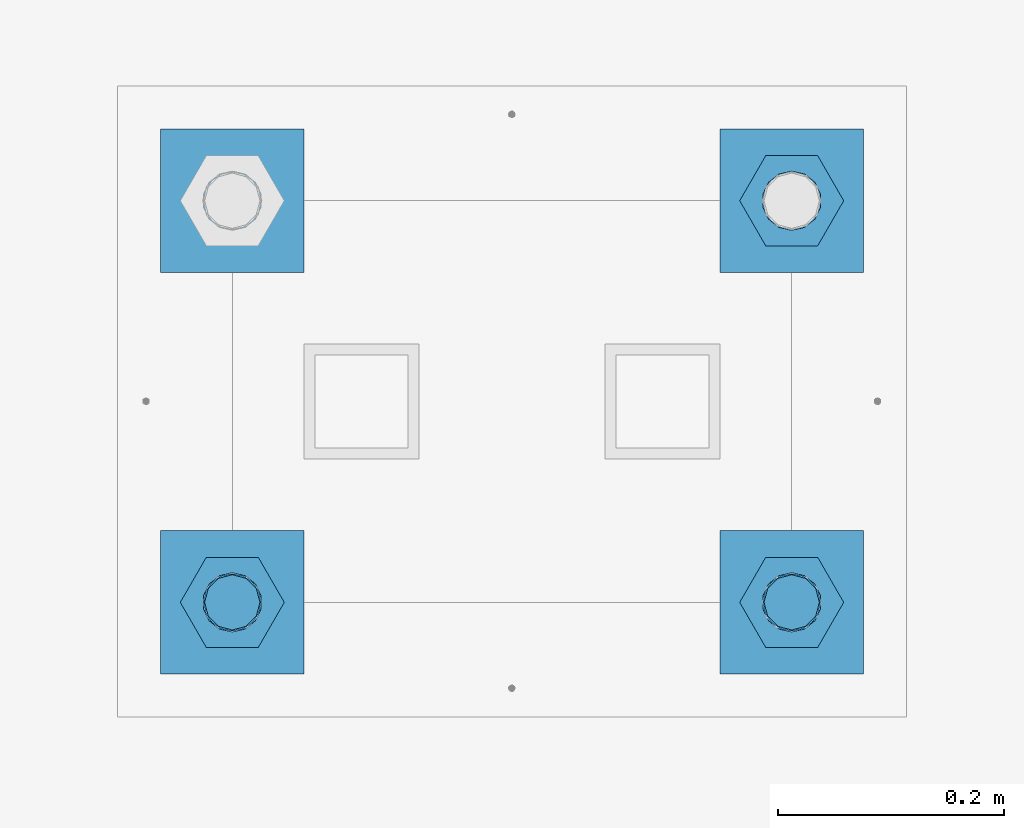
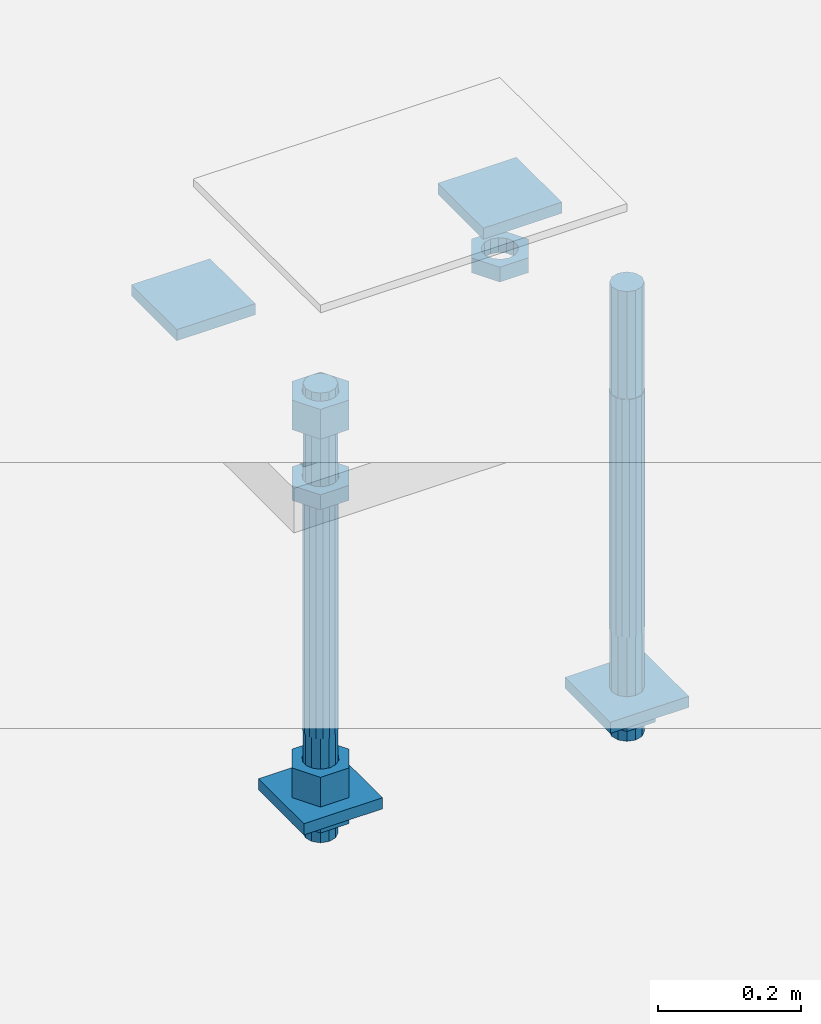
# One storey, part 2704 of 3843: 12 beams, 1 element without a shape of its own.
"""IFC2X3 building model written with IfcOpenShell, lengths in millimetres."""

from ifc_helpers import new_model, si_unit, frame, origin_with_axes, place, context, subcontext, project, spatial, faceted_brep, material, type_object, element, aggregate, save


model = new_model("IFC2X3")

# Units and contexts
model_context = context("Model", 3, precision=1e-05, world=origin_with_axes())
body_context = subcontext(model_context, "Body", "Model", "MODEL_VIEW")
ifc_project = project(units=[si_unit("LENGTHUNIT", "METRE", prefix="MILLI"), si_unit("AREAUNIT", "SQUARE_METRE"), si_unit("VOLUMEUNIT", "CUBIC_METRE"), si_unit("MASSUNIT", "GRAM", prefix="KILO"), si_unit("TIMEUNIT", "SECOND"), si_unit("PLANEANGLEUNIT", "RADIAN"), si_unit("SOLIDANGLEUNIT", "STERADIAN"), si_unit("THERMODYNAMICTEMPERATUREUNIT", "DEGREE_CELSIUS"), si_unit("LUMINOUSINTENSITYUNIT", "LUMEN")], contexts=[model_context])

# Site, building, storey
site_placement = place(None, origin_with_axes())
site = spatial("IfcSite", under=ifc_project, at=site_placement, CompositionType="ELEMENT")
building_placement = place(site_placement, origin_with_axes())
building = spatial("IfcBuilding", under=site, at=building_placement, Name="Undefined", CompositionType="ELEMENT")
storey_placement = place(building_placement, origin_with_axes())
storey = spatial("IfcBuildingStorey", under=building, at=storey_placement, Name="Undefined", CompositionType="ELEMENT", Elevation=0.0)

# Assembly, beams
assembly_placement = place(storey_placement, origin_with_axes())
assembly = element("IfcElementAssembly", 1, at=assembly_placement, inside=storey, Name="TEMPLATE", AssemblyPlace="NOTDEFINED", PredefinedType="RIGID_FRAME")
ifc_material_1 = material(Name="STEEL/A572-50")
beam_type_1 = type_object("IfcBeamType", PredefinedType="NOTDEFINED")
beam_1_placement = place(assembly_placement, frame((105403.65, 45910.4999984741, 29873.575), z_axis=(-1.0, 0.0, 0.0), x_axis=(0.0, -1.0, 0.0)))
beam_1 = element("IfcBeam", 2, at=beam_1_placement, type_object=beam_type_1, material=ifc_material_1, Name="WASHER_PLATE", context=body_context, shape_type="Brep", body=[
    faceted_brep([(0.0, 9.52500000000146, -63.5), (0.0, 9.52500000000146, 63.5), (127.0, 9.52500000000146, 63.5), (127.0, 9.52500000000146, -63.5), (0.0, -9.52500000000146, 63.5), (127.0, -9.52500000000146, 63.5), (0.0, -9.52500000000146, -63.5), (127.0, -9.52500000000146, -63.5)], [[[0, 1, 2, 3]], [[1, 4, 5, 2]], [[4, 6, 7, 5]], [[6, 0, 3, 7]], [[5, 7, 3, 2]], [[6, 4, 1, 0]]]),
])
beam_2_placement = place(assembly_placement, frame((104908.35, 45910.4999984741, 29873.575), z_axis=(-1.0, 0.0, 0.0), x_axis=(0.0, -1.0, 0.0)))
beam_2 = element("IfcBeam", 3, at=beam_2_placement, type_object=beam_type_1, material=ifc_material_1, Name="WASHER_PLATE", context=body_context, shape_type="Brep", body=[
    faceted_brep([(0.0, 9.52500000000146, -63.5), (0.0, 9.52500000000146, 63.5), (127.0, 9.52500000000146, 63.5), (127.0, 9.52500000000146, -63.5), (0.0, -9.52500000000146, 63.5), (127.0, -9.52500000000146, 63.5), (0.0, -9.52500000000146, -63.5), (127.0, -9.52500000000146, -63.5)], [[[0, 1, 2, 3]], [[1, 4, 5, 2]], [[4, 6, 7, 5]], [[6, 0, 3, 7]], [[5, 7, 3, 2]], [[6, 4, 1, 0]]]),
])
beam_3_placement = place(assembly_placement, frame((105403.65, 45554.8999984741, 29244.925), z_axis=(-1.0, 0.0, 0.0), x_axis=(0.0, -1.0, 0.0)))
beam_3 = element("IfcBeam", 4, at=beam_3_placement, type_object=beam_type_1, material=ifc_material_1, Name="WASHER_PLATE", context=body_context, shape_type="Brep", body=[
    faceted_brep([(0.0, 9.52500000000146, -63.5), (0.0, 9.52500000000146, 63.5), (127.0, 9.52500000000146, 63.5), (127.0, 9.52500000000146, -63.5), (0.0, -9.52500000000146, 63.5), (127.0, -9.52500000000146, 63.5), (0.0, -9.52500000000146, -63.5), (127.0, -9.52500000000146, -63.5)], [[[0, 1, 2, 3]], [[1, 4, 5, 2]], [[4, 6, 7, 5]], [[6, 0, 3, 7]], [[5, 7, 3, 2]], [[6, 4, 1, 0]]]),
])
beam_4_placement = place(assembly_placement, frame((104908.35, 45554.8999984741, 29244.925), z_axis=(-1.0, 0.0, 0.0), x_axis=(0.0, -1.0, 0.0)))
beam_4 = element("IfcBeam", 5, at=beam_4_placement, type_object=beam_type_1, material=ifc_material_1, Name="WASHER_PLATE", context=body_context, shape_type="Brep", body=[
    faceted_brep([(0.0, 9.52500000000146, -63.5), (0.0, 9.52500000000146, 63.5), (127.0, 9.52500000000146, 63.5), (127.0, 9.52500000000146, -63.5), (0.0, -9.52500000000146, 63.5), (127.0, -9.52500000000146, 63.5), (0.0, -9.52500000000146, -63.5), (127.0, -9.52500000000146, -63.5)], [[[0, 1, 2, 3]], [[1, 4, 5, 2]], [[4, 6, 7, 5]], [[6, 0, 3, 7]], [[5, 7, 3, 2]], [[6, 4, 1, 0]]]),
])
ifc_material_2 = material(Name="STEEL/A36")
beam_type_2 = type_object("IfcBeamType", Name="2_HALF_NUT", PredefinedType="NOTDEFINED")
beam_5_placement = place(assembly_placement, frame((105403.65, 45846.9999984741, 29787.85), z_axis=(0.0, -1.0, 0.0), x_axis=(0.0, 0.0, -1.0)))
beam_5 = element("IfcBeam", 6, at=beam_5_placement, type_object=beam_type_2, material=ifc_material_2, Name="NUT", ObjectType="2_HALF_NUT", context=body_context, shape_type="Brep", body=[
    faceted_brep([(0.0, -46.0369987487793, 0.0), (0.0, -23.0184993743896, -39.869213104248), (25.4000000000015, -23.0184993743896, -39.869213104248), (25.4000000000015, -46.0369987487793, 0.0), (0.0, 23.0184993743896, -39.869213104248), (25.4000000000015, 23.0184993743896, -39.869213104248), (0.0, 46.0369987487793, 0.0), (25.4000000000015, 46.0369987487793, 0.0), (0.0, 23.0184993743896, 39.869213104248), (25.4000000000015, 23.0184993743896, 39.869213104248), (0.0, -23.0184993743896, 39.869213104248), (25.4000000000015, -23.0184993743896, 39.869213104248), (0.0, 0.0, 26.1940002441406), (0.0, 11.3650617044477, 23.5999013092805), (25.4000000000015, 11.3650617044477, 23.5999013092805), (25.4000000000015, 0.0, 26.1940002441406), (0.0, 20.4791109456419, 16.3316083006721), (25.4000000000015, 20.4791109456419, 16.3316083006721), (0.0, 25.5370200498292, 5.82867859874386), (25.4000000000015, 25.5370200498292, 5.82867859874386), (0.0, 25.5370200498292, -5.82867859874386), (25.4000000000015, 25.5370200498292, -5.82867859874386), (0.0, 20.4791109456419, -16.3316083006721), (25.4000000000015, 20.4791109456419, -16.3316083006721), (0.0, 11.3650617044477, -23.5999013092805), (25.4000000000015, 11.3650617044477, -23.5999013092805), (0.0, 0.0, -26.1940002441406), (25.4000000000015, 0.0, -26.1940002441406), (0.0, -11.3650617044477, -23.5999013092805), (25.4000000000015, -11.3650617044477, -23.5999013092805), (0.0, -20.4791109456419, -16.3316083006721), (25.4000000000015, -20.4791109456419, -16.3316083006721), (0.0, -25.5370200498292, -5.82867859874386), (25.4000000000015, -25.5370200498292, -5.82867859874386), (0.0, -25.5370200498292, 5.82867859874386), (25.4000000000015, -25.5370200498292, 5.82867859874386), (0.0, -20.4791109456419, 16.3316083006721), (25.4000000000015, -20.4791109456419, 16.3316083006721), (0.0, -11.3650617044477, 23.5999013092805), (25.4000000000015, -11.3650617044477, 23.5999013092805)], [[[0, 1, 2, 3]], [[1, 4, 5, 2]], [[4, 6, 7, 5]], [[6, 8, 9, 7]], [[8, 10, 11, 9]], [[10, 0, 3, 11]], [[12, 13, 14, 15]], [[13, 16, 17, 14]], [[16, 18, 19, 17]], [[18, 20, 21, 19]], [[20, 22, 23, 21]], [[22, 24, 25, 23]], [[24, 26, 27, 25]], [[26, 28, 29, 27]], [[28, 30, 31, 29]], [[30, 32, 33, 31]], [[32, 34, 35, 33]], [[34, 36, 37, 35]], [[36, 38, 39, 37]], [[38, 12, 15, 39]], [[5, 7, 9, 11, 3, 2], [17, 19, 21, 23, 25, 27, 29, 31, 33, 35, 37, 39, 15, 14]], [[10, 8, 6, 4, 1, 0], [38, 36, 34, 32, 30, 28, 26, 24, 22, 20, 18, 16, 13, 12]]]),
])
beam_6_placement = place(assembly_placement, frame((105403.65, 45491.3999984741, 29235.4), z_axis=(0.0, -1.0, 0.0), x_axis=(0.0, 0.0, -1.0)))
beam_6 = element("IfcBeam", 7, at=beam_6_placement, type_object=beam_type_2, material=ifc_material_2, Name="NUT", ObjectType="2_HALF_NUT", context=body_context, shape_type="Brep", body=[
    faceted_brep([(0.0, -46.0369987487793, 0.0), (0.0, -23.0184993743896, -39.869213104248), (25.4000000000015, -23.0184993743896, -39.869213104248), (25.4000000000015, -46.0369987487793, 0.0), (0.0, 23.0184993743896, -39.869213104248), (25.4000000000015, 23.0184993743896, -39.869213104248), (0.0, 46.0369987487793, 0.0), (25.4000000000015, 46.0369987487793, 0.0), (0.0, 23.0184993743896, 39.869213104248), (25.4000000000015, 23.0184993743896, 39.869213104248), (0.0, -23.0184993743896, 39.869213104248), (25.4000000000015, -23.0184993743896, 39.869213104248), (0.0, 0.0, 26.1940002441406), (0.0, 11.3650617044477, 23.5999013092805), (25.4000000000015, 11.3650617044477, 23.5999013092805), (25.4000000000015, 0.0, 26.1940002441406), (0.0, 20.4791109456419, 16.3316083006721), (25.4000000000015, 20.4791109456419, 16.3316083006721), (0.0, 25.5370200498292, 5.82867859874386), (25.4000000000015, 25.5370200498292, 5.82867859874386), (0.0, 25.5370200498292, -5.82867859874386), (25.4000000000015, 25.5370200498292, -5.82867859874386), (0.0, 20.4791109456419, -16.3316083006721), (25.4000000000015, 20.4791109456419, -16.3316083006721), (0.0, 11.3650617044477, -23.5999013092805), (25.4000000000015, 11.3650617044477, -23.5999013092805), (0.0, 0.0, -26.1940002441406), (25.4000000000015, 0.0, -26.1940002441406), (0.0, -11.3650617044477, -23.5999013092805), (25.4000000000015, -11.3650617044477, -23.5999013092805), (0.0, -20.4791109456419, -16.3316083006721), (25.4000000000015, -20.4791109456419, -16.3316083006721), (0.0, -25.5370200498292, -5.82867859874386), (25.4000000000015, -25.5370200498292, -5.82867859874386), (0.0, -25.5370200498292, 5.82867859874386), (25.4000000000015, -25.5370200498292, 5.82867859874386), (0.0, -20.4791109456419, 16.3316083006721), (25.4000000000015, -20.4791109456419, 16.3316083006721), (0.0, -11.3650617044477, 23.5999013092805), (25.4000000000015, -11.3650617044477, 23.5999013092805)], [[[0, 1, 2, 3]], [[1, 4, 5, 2]], [[4, 6, 7, 5]], [[6, 8, 9, 7]], [[8, 10, 11, 9]], [[10, 0, 3, 11]], [[12, 13, 14, 15]], [[13, 16, 17, 14]], [[16, 18, 19, 17]], [[18, 20, 21, 19]], [[20, 22, 23, 21]], [[22, 24, 25, 23]], [[24, 26, 27, 25]], [[26, 28, 29, 27]], [[28, 30, 31, 29]], [[30, 32, 33, 31]], [[32, 34, 35, 33]], [[34, 36, 37, 35]], [[36, 38, 39, 37]], [[38, 12, 15, 39]], [[5, 7, 9, 11, 3, 2], [17, 19, 21, 23, 25, 27, 29, 31, 33, 35, 37, 39, 15, 14]], [[10, 8, 6, 4, 1, 0], [38, 36, 34, 32, 30, 28, 26, 24, 22, 20, 18, 16, 13, 12]]]),
])
beam_7_placement = place(assembly_placement, frame((104908.35, 45491.3999984741, 29787.85), z_axis=(0.0, -1.0, 0.0), x_axis=(0.0, 0.0, -1.0)))
beam_7 = element("IfcBeam", 8, at=beam_7_placement, type_object=beam_type_2, material=ifc_material_2, Name="NUT", ObjectType="2_HALF_NUT", context=body_context, shape_type="Brep", body=[
    faceted_brep([(0.0, -46.0369987487793, 0.0), (0.0, -23.0184993743896, -39.869213104248), (25.4000000000015, -23.0184993743896, -39.869213104248), (25.4000000000015, -46.0369987487793, 0.0), (0.0, 23.0184993743896, -39.869213104248), (25.4000000000015, 23.0184993743896, -39.869213104248), (0.0, 46.0369987487793, 0.0), (25.4000000000015, 46.0369987487793, 0.0), (0.0, 23.0184993743896, 39.869213104248), (25.4000000000015, 23.0184993743896, 39.869213104248), (0.0, -23.0184993743896, 39.869213104248), (25.4000000000015, -23.0184993743896, 39.869213104248), (0.0, 0.0, 26.1940002441406), (0.0, 11.3650617044477, 23.5999013092805), (25.4000000000015, 11.3650617044477, 23.5999013092805), (25.4000000000015, 0.0, 26.1940002441406), (0.0, 20.4791109456419, 16.3316083006721), (25.4000000000015, 20.4791109456419, 16.3316083006721), (0.0, 25.5370200498292, 5.82867859874386), (25.4000000000015, 25.5370200498292, 5.82867859874386), (0.0, 25.5370200498292, -5.82867859874386), (25.4000000000015, 25.5370200498292, -5.82867859874386), (0.0, 20.4791109456419, -16.3316083006721), (25.4000000000015, 20.4791109456419, -16.3316083006721), (0.0, 11.3650617044477, -23.5999013092805), (25.4000000000015, 11.3650617044477, -23.5999013092805), (0.0, 0.0, -26.1940002441406), (25.4000000000015, 0.0, -26.1940002441406), (0.0, -11.3650617044477, -23.5999013092805), (25.4000000000015, -11.3650617044477, -23.5999013092805), (0.0, -20.4791109456419, -16.3316083006721), (25.4000000000015, -20.4791109456419, -16.3316083006721), (0.0, -25.5370200498292, -5.82867859874386), (25.4000000000015, -25.5370200498292, -5.82867859874386), (0.0, -25.5370200498292, 5.82867859874386), (25.4000000000015, -25.5370200498292, 5.82867859874386), (0.0, -20.4791109456419, 16.3316083006721), (25.4000000000015, -20.4791109456419, 16.3316083006721), (0.0, -11.3650617044477, 23.5999013092805), (25.4000000000015, -11.3650617044477, 23.5999013092805)], [[[0, 1, 2, 3]], [[1, 4, 5, 2]], [[4, 6, 7, 5]], [[6, 8, 9, 7]], [[8, 10, 11, 9]], [[10, 0, 3, 11]], [[12, 13, 14, 15]], [[13, 16, 17, 14]], [[16, 18, 19, 17]], [[18, 20, 21, 19]], [[20, 22, 23, 21]], [[22, 24, 25, 23]], [[24, 26, 27, 25]], [[26, 28, 29, 27]], [[28, 30, 31, 29]], [[30, 32, 33, 31]], [[32, 34, 35, 33]], [[34, 36, 37, 35]], [[36, 38, 39, 37]], [[38, 12, 15, 39]], [[5, 7, 9, 11, 3, 2], [17, 19, 21, 23, 25, 27, 29, 31, 33, 35, 37, 39, 15, 14]], [[10, 8, 6, 4, 1, 0], [38, 36, 34, 32, 30, 28, 26, 24, 22, 20, 18, 16, 13, 12]]]),
])
beam_8_placement = place(assembly_placement, frame((104908.35, 45491.3999984741, 29235.4), z_axis=(0.0, -1.0, 0.0), x_axis=(0.0, 0.0, -1.0)))
beam_8 = element("IfcBeam", 9, at=beam_8_placement, type_object=beam_type_2, material=ifc_material_2, Name="NUT", ObjectType="2_HALF_NUT", context=body_context, shape_type="Brep", body=[
    faceted_brep([(0.0, -46.0369987487793, 0.0), (0.0, -23.0184993743896, -39.869213104248), (25.4000000000015, -23.0184993743896, -39.869213104248), (25.4000000000015, -46.0369987487793, 0.0), (0.0, 23.0184993743896, -39.869213104248), (25.4000000000015, 23.0184993743896, -39.869213104248), (0.0, 46.0369987487793, 0.0), (25.4000000000015, 46.0369987487793, 0.0), (0.0, 23.0184993743896, 39.869213104248), (25.4000000000015, 23.0184993743896, 39.869213104248), (0.0, -23.0184993743896, 39.869213104248), (25.4000000000015, -23.0184993743896, 39.869213104248), (0.0, 0.0, 26.1940002441406), (0.0, 11.3650617044477, 23.5999013092805), (25.4000000000015, 11.3650617044477, 23.5999013092805), (25.4000000000015, 0.0, 26.1940002441406), (0.0, 20.4791109456419, 16.3316083006721), (25.4000000000015, 20.4791109456419, 16.3316083006721), (0.0, 25.5370200498292, 5.82867859874386), (25.4000000000015, 25.5370200498292, 5.82867859874386), (0.0, 25.5370200498292, -5.82867859874386), (25.4000000000015, 25.5370200498292, -5.82867859874386), (0.0, 20.4791109456419, -16.3316083006721), (25.4000000000015, 20.4791109456419, -16.3316083006721), (0.0, 11.3650617044477, -23.5999013092805), (25.4000000000015, 11.3650617044477, -23.5999013092805), (0.0, 0.0, -26.1940002441406), (25.4000000000015, 0.0, -26.1940002441406), (0.0, -11.3650617044477, -23.5999013092805), (25.4000000000015, -11.3650617044477, -23.5999013092805), (0.0, -20.4791109456419, -16.3316083006721), (25.4000000000015, -20.4791109456419, -16.3316083006721), (0.0, -25.5370200498292, -5.82867859874386), (25.4000000000015, -25.5370200498292, -5.82867859874386), (0.0, -25.5370200498292, 5.82867859874386), (25.4000000000015, -25.5370200498292, 5.82867859874386), (0.0, -20.4791109456419, 16.3316083006721), (25.4000000000015, -20.4791109456419, 16.3316083006721), (0.0, -11.3650617044477, 23.5999013092805), (25.4000000000015, -11.3650617044477, 23.5999013092805)], [[[0, 1, 2, 3]], [[1, 4, 5, 2]], [[4, 6, 7, 5]], [[6, 8, 9, 7]], [[8, 10, 11, 9]], [[10, 0, 3, 11]], [[12, 13, 14, 15]], [[13, 16, 17, 14]], [[16, 18, 19, 17]], [[18, 20, 21, 19]], [[20, 22, 23, 21]], [[22, 24, 25, 23]], [[24, 26, 27, 25]], [[26, 28, 29, 27]], [[28, 30, 31, 29]], [[30, 32, 33, 31]], [[32, 34, 35, 33]], [[34, 36, 37, 35]], [[36, 38, 39, 37]], [[38, 12, 15, 39]], [[5, 7, 9, 11, 3, 2], [17, 19, 21, 23, 25, 27, 29, 31, 33, 35, 37, 39, 15, 14]], [[10, 8, 6, 4, 1, 0], [38, 36, 34, 32, 30, 28, 26, 24, 22, 20, 18, 16, 13, 12]]]),
])
beam_type_3 = type_object("IfcBeamType", Name="2_HEAVY_HEX_NUT", PredefinedType="NOTDEFINED")
beam_9_placement = place(assembly_placement, frame((104908.35, 45491.3999984741, 29933.9), z_axis=(0.0, -1.0, 0.0), x_axis=(0.0, 0.0, -1.0)))
beam_9 = element("IfcBeam", 10, at=beam_9_placement, type_object=beam_type_3, material=ifc_material_2, Name="NUT", ObjectType="2_HEAVY_HEX_NUT", context=body_context, shape_type="Brep", body=[
    faceted_brep([(0.0, -46.0369987487793, 0.0), (0.0, -23.0184993743896, -39.869213104248), (50.7999999999993, -23.0184993743896, -39.869213104248), (50.7999999999993, -46.0369987487793, 0.0), (0.0, 23.0184993743896, -39.869213104248), (50.7999999999993, 23.0184993743896, -39.869213104248), (0.0, 46.0369987487793, 0.0), (50.7999999999993, 46.0369987487793, 0.0), (0.0, 23.0184993743896, 39.869213104248), (50.7999999999993, 23.0184993743896, 39.869213104248), (0.0, -23.0184993743896, 39.869213104248), (50.7999999999993, -23.0184993743896, 39.869213104248), (0.0, 0.0, 26.1940002441406), (0.0, 11.3650617044477, 23.5999013092805), (50.7999999999993, 11.3650617044477, 23.5999013092805), (50.7999999999993, 0.0, 26.1940002441406), (0.0, 20.4791109456419, 16.3316083006721), (50.7999999999993, 20.4791109456419, 16.3316083006721), (0.0, 25.5370200498292, 5.82867859874386), (50.7999999999993, 25.5370200498292, 5.82867859874386), (0.0, 25.5370200498292, -5.82867859874386), (50.7999999999993, 25.5370200498292, -5.82867859874386), (0.0, 20.4791109456419, -16.3316083006721), (50.7999999999993, 20.4791109456419, -16.3316083006721), (0.0, 11.3650617044477, -23.5999013092805), (50.7999999999993, 11.3650617044477, -23.5999013092805), (0.0, 0.0, -26.1940002441406), (50.7999999999993, 0.0, -26.1940002441406), (0.0, -11.3650617044477, -23.5999013092805), (50.7999999999993, -11.3650617044477, -23.5999013092805), (0.0, -20.4791109456419, -16.3316083006721), (50.7999999999993, -20.4791109456419, -16.3316083006721), (0.0, -25.5370200498292, -5.82867859874386), (50.7999999999993, -25.5370200498292, -5.82867859874386), (0.0, -25.5370200498292, 5.82867859874386), (50.7999999999993, -25.5370200498292, 5.82867859874386), (0.0, -20.4791109456419, 16.3316083006721), (50.7999999999993, -20.4791109456419, 16.3316083006721), (0.0, -11.3650617044477, 23.5999013092805), (50.7999999999993, -11.3650617044477, 23.5999013092805)], [[[0, 1, 2, 3]], [[1, 4, 5, 2]], [[4, 6, 7, 5]], [[6, 8, 9, 7]], [[8, 10, 11, 9]], [[10, 0, 3, 11]], [[12, 13, 14, 15]], [[13, 16, 17, 14]], [[16, 18, 19, 17]], [[18, 20, 21, 19]], [[20, 22, 23, 21]], [[22, 24, 25, 23]], [[24, 26, 27, 25]], [[26, 28, 29, 27]], [[28, 30, 31, 29]], [[30, 32, 33, 31]], [[32, 34, 35, 33]], [[34, 36, 37, 35]], [[36, 38, 39, 37]], [[38, 12, 15, 39]], [[5, 7, 9, 11, 3, 2], [17, 19, 21, 23, 25, 27, 29, 31, 33, 35, 37, 39, 15, 14]], [[10, 8, 6, 4, 1, 0], [38, 36, 34, 32, 30, 28, 26, 24, 22, 20, 18, 16, 13, 12]]]),
])
beam_10_placement = place(assembly_placement, frame((104908.35, 45491.3999984741, 29305.25), z_axis=(0.0, -1.0, 0.0), x_axis=(0.0, 0.0, -1.0)))
beam_10 = element("IfcBeam", 11, at=beam_10_placement, type_object=beam_type_3, material=ifc_material_2, Name="NUT", ObjectType="2_HEAVY_HEX_NUT", context=body_context, shape_type="Brep", body=[
    faceted_brep([(0.0, -46.0369987487793, 0.0), (0.0, -23.0184993743896, -39.869213104248), (50.7999999999993, -23.0184993743896, -39.869213104248), (50.7999999999993, -46.0369987487793, 0.0), (0.0, 23.0184993743896, -39.869213104248), (50.7999999999993, 23.0184993743896, -39.869213104248), (0.0, 46.0369987487793, 0.0), (50.7999999999993, 46.0369987487793, 0.0), (0.0, 23.0184993743896, 39.869213104248), (50.7999999999993, 23.0184993743896, 39.869213104248), (0.0, -23.0184993743896, 39.869213104248), (50.7999999999993, -23.0184993743896, 39.869213104248), (0.0, 0.0, 26.1940002441406), (0.0, 11.3650617044477, 23.5999013092805), (50.7999999999993, 11.3650617044477, 23.5999013092805), (50.7999999999993, 0.0, 26.1940002441406), (0.0, 20.4791109456419, 16.3316083006721), (50.7999999999993, 20.4791109456419, 16.3316083006721), (0.0, 25.5370200498292, 5.82867859874386), (50.7999999999993, 25.5370200498292, 5.82867859874386), (0.0, 25.5370200498292, -5.82867859874386), (50.7999999999993, 25.5370200498292, -5.82867859874386), (0.0, 20.4791109456419, -16.3316083006721), (50.7999999999993, 20.4791109456419, -16.3316083006721), (0.0, 11.3650617044477, -23.5999013092805), (50.7999999999993, 11.3650617044477, -23.5999013092805), (0.0, 0.0, -26.1940002441406), (50.7999999999993, 0.0, -26.1940002441406), (0.0, -11.3650617044477, -23.5999013092805), (50.7999999999993, -11.3650617044477, -23.5999013092805), (0.0, -20.4791109456419, -16.3316083006721), (50.7999999999993, -20.4791109456419, -16.3316083006721), (0.0, -25.5370200498292, -5.82867859874386), (50.7999999999993, -25.5370200498292, -5.82867859874386), (0.0, -25.5370200498292, 5.82867859874386), (50.7999999999993, -25.5370200498292, 5.82867859874386), (0.0, -20.4791109456419, 16.3316083006721), (50.7999999999993, -20.4791109456419, 16.3316083006721), (0.0, -11.3650617044477, 23.5999013092805), (50.7999999999993, -11.3650617044477, 23.5999013092805)], [[[0, 1, 2, 3]], [[1, 4, 5, 2]], [[4, 6, 7, 5]], [[6, 8, 9, 7]], [[8, 10, 11, 9]], [[10, 0, 3, 11]], [[12, 13, 14, 15]], [[13, 16, 17, 14]], [[16, 18, 19, 17]], [[18, 20, 21, 19]], [[20, 22, 23, 21]], [[22, 24, 25, 23]], [[24, 26, 27, 25]], [[26, 28, 29, 27]], [[28, 30, 31, 29]], [[30, 32, 33, 31]], [[32, 34, 35, 33]], [[34, 36, 37, 35]], [[36, 38, 39, 37]], [[38, 12, 15, 39]], [[5, 7, 9, 11, 3, 2], [17, 19, 21, 23, 25, 27, 29, 31, 33, 35, 37, 39, 15, 14]], [[10, 8, 6, 4, 1, 0], [38, 36, 34, 32, 30, 28, 26, 24, 22, 20, 18, 16, 13, 12]]]),
])
ifc_material_3 = material()
beam_type_4 = type_object("IfcBeamType", PredefinedType="NOTDEFINED")
beam_11_placement = place(assembly_placement, frame((105403.65, 45491.3999984741, 29762.45), z_axis=(0.0, -1.0, 0.0), x_axis=(0.0, 0.0, -1.0)))
beam_11 = element("IfcBeam", 12, at=beam_11_placement, type_object=beam_type_4, material=ifc_material_3, Name="ANCHOR_ROD", context=body_context, shape_type="Brep", body=[
    faceted_brep([(-184.150000000001, -21.217622392709, 12.25), (-184.150000000001, -12.2499999999854, 21.2176223927163), (-184.150000000001, 1.45519152283669e-11, 24.5), (-184.150000000001, 12.2500000000146, 21.2176223927163), (-184.150000000001, 21.2176223927381, 12.25), (-184.150000000001, 24.5000000000146, 0.0), (-184.150000000001, 21.2176223927381, -12.25), (-184.150000000001, 12.2500000000146, -21.2176223927163), (-184.150000000001, 1.45519152283669e-11, -24.5), (-184.150000000001, -12.2499999999854, -21.2176223927163), (-184.150000000001, -21.217622392709, -12.25), (-184.150000000001, -24.4999999999854, 0.0), (0.0, 24.5000000000146, 0.0), (0.0, 21.2176223927381, -12.25), (0.0, 12.2500000000146, -21.2176223927163), (0.0, 1.45519152283669e-11, -24.5), (0.0, -12.2499999999854, -21.2176223927163), (0.0, -21.217622392709, -12.25), (0.0, -24.4999999999854, 0.0), (0.0, -21.217622392709, 12.25), (0.0, -12.2499999999854, 21.2176223927163), (0.0, 1.45519152283669e-11, 24.5), (0.0, 12.2500000000146, 21.2176223927163), (0.0, 21.2176223927381, 12.25), (0.0, -23.4665401257807, 9.72015918207035), (0.0, -17.9605122421344, 17.9605122421417), (0.0, -9.72015918207762, 23.466540125788), (0.0, 0.0, 25.4000000000015), (0.0, 9.72015918207762, 23.466540125788), (0.0, 17.9605122421344, 17.9605122421417), (0.0, 23.4665401257807, 9.72015918207035), (0.0, 25.3999996185303, 0.0), (0.0, 23.4665401257807, -9.72015918207035), (0.0, 17.9605122421344, -17.9605122421417), (0.0, 9.72015918207762, -23.466540125788), (0.0, 0.0, -25.4000000000015), (0.0, -9.72015918207762, -23.466540125788), (0.0, -17.9605122421344, -17.9605122421417), (0.0, -23.4665401257807, -9.72015918207035), (0.0, -25.3999996185303, 0.0), (406.399999999998, -25.3999999999942, 0.0), (406.399999999998, -23.4665401257807, 9.72015918207035), (406.399999999998, -17.9605122421344, 17.9605122421417), (406.399999999998, -9.72015918207762, 23.466540125788), (406.399999999998, 0.0, 25.4000000000015), (406.399999999998, 9.72015918207762, 23.466540125788), (406.399999999998, 17.9605122421344, 17.9605122421417), (406.399999999998, 23.4665401257807, 9.72015918207035), (406.399999999998, 25.3999999999942, 0.0), (406.399999999998, 23.4665401257807, -9.72015918207035), (406.399999999998, 17.9605122421344, -17.9605122421417), (406.399999999998, 9.72015918207762, -23.466540125788), (406.399999999998, 0.0, -25.4000000000015), (406.399999999998, -9.72015918207762, -23.466540125788), (406.399999999998, -17.9605122421344, -17.9605122421417), (406.399999999998, -23.4665401257807, -9.72015918207035), (406.399999999998, -12.2499999999854, 21.2176223927163), (406.399999999998, 1.45519152283669e-11, 24.5), (406.399999999998, 12.2500000000146, 21.2176223927163), (406.399999999998, 21.2176223927381, 12.25), (406.399999999998, 24.5000000000146, 0.0), (406.399999999998, 21.2176223927381, -12.25), (406.399999999998, 12.2500000000146, -21.2176223927163), (406.399999999998, 1.45519152283669e-11, -24.5), (406.399999999998, -12.2499999999854, -21.2176223927163), (406.399999999998, -21.217622392709, -12.25), (406.399999999998, -24.4999999999854, 0.0), (406.399999999998, -21.217622392709, 12.25), (584.200000000001, -12.2499999999854, -21.2176223927163), (584.200000000001, 1.45519152283669e-11, -24.5), (584.200000000001, 12.2500000000146, -21.2176223927163), (584.200000000001, 21.2176223927381, -12.25), (584.200000000001, 24.5000000000146, 0.0), (584.200000000001, 21.2176223927381, 12.25), (584.200000000001, 12.2500000000146, 21.2176223927163), (584.200000000001, 1.45519152283669e-11, 24.5), (584.200000000001, -12.2499999999854, 21.2176223927163), (584.200000000001, -21.217622392709, 12.25), (584.200000000001, -24.4999999999854, 0.0), (584.200000000001, -21.217622392709, -12.25)], [[[0, 1, 2, 3, 4, 5, 6, 7, 8, 9, 10, 11]], [[6, 5, 12, 13]], [[7, 6, 13, 14]], [[8, 7, 14, 15]], [[9, 8, 15, 16]], [[10, 9, 16, 17]], [[11, 10, 17, 18]], [[0, 11, 18, 19]], [[1, 0, 19, 20]], [[2, 1, 20, 21]], [[3, 2, 21, 22]], [[4, 3, 22, 23]], [[5, 4, 23, 12]], [[24, 25, 26, 27, 28, 29, 30, 31, 32, 33, 34, 35, 36, 37, 38, 39], [22, 21, 20, 19, 18, 17, 16, 15, 14, 13, 12, 23]], [[24, 39, 40, 41]], [[25, 24, 41, 42]], [[26, 25, 42, 43]], [[27, 26, 43, 44]], [[28, 27, 44, 45]], [[29, 28, 45, 46]], [[30, 29, 46, 47]], [[31, 30, 47, 48]], [[32, 31, 48, 49]], [[33, 32, 49, 50]], [[34, 33, 50, 51]], [[35, 34, 51, 52]], [[36, 35, 52, 53]], [[37, 36, 53, 54]], [[38, 37, 54, 55]], [[39, 38, 55, 40]], [[54, 53, 52, 51, 50, 49, 48, 47, 46, 45, 44, 43, 42, 41, 40, 55], [56, 57, 58, 59, 60, 61, 62, 63, 64, 65, 66, 67]], [[68, 69, 70, 71, 72, 73, 74, 75, 76, 77, 78, 79]], [[76, 75, 57, 56]], [[77, 76, 56, 67]], [[78, 77, 67, 66]], [[79, 78, 66, 65]], [[68, 79, 65, 64]], [[69, 68, 64, 63]], [[70, 69, 63, 62]], [[71, 70, 62, 61]], [[72, 71, 61, 60]], [[73, 72, 60, 59]], [[74, 73, 59, 58]], [[75, 74, 58, 57]]]),
])
beam_12_placement = place(assembly_placement, frame((104908.35, 45491.3999984741, 29762.45), z_axis=(0.0, -1.0, 0.0), x_axis=(0.0, 0.0, -1.0)))
beam_12 = element("IfcBeam", 13, at=beam_12_placement, type_object=beam_type_4, material=ifc_material_3, Name="ANCHOR_ROD", context=body_context, shape_type="Brep", body=[
    faceted_brep([(-184.150000000001, -21.217622392709, 12.25), (-184.150000000001, -12.2499999999854, 21.2176223927163), (-184.150000000001, 1.45519152283669e-11, 24.5), (-184.150000000001, 12.2500000000146, 21.2176223927163), (-184.150000000001, 21.2176223927381, 12.25), (-184.150000000001, 24.5000000000146, 0.0), (-184.150000000001, 21.2176223927381, -12.25), (-184.150000000001, 12.2500000000146, -21.2176223927163), (-184.150000000001, 1.45519152283669e-11, -24.5), (-184.150000000001, -12.2499999999854, -21.2176223927163), (-184.150000000001, -21.217622392709, -12.25), (-184.150000000001, -24.4999999999854, 0.0), (0.0, 24.5000000000146, 0.0), (0.0, 21.2176223927381, -12.25), (0.0, 12.2500000000146, -21.2176223927163), (0.0, 1.45519152283669e-11, -24.5), (0.0, -12.2499999999854, -21.2176223927163), (0.0, -21.217622392709, -12.25), (0.0, -24.4999999999854, 0.0), (0.0, -21.217622392709, 12.25), (0.0, -12.2499999999854, 21.2176223927163), (0.0, 1.45519152283669e-11, 24.5), (0.0, 12.2500000000146, 21.2176223927163), (0.0, 21.2176223927381, 12.25), (0.0, -23.4665401257807, 9.72015918207035), (0.0, -17.9605122421344, 17.9605122421417), (0.0, -9.72015918207762, 23.466540125788), (0.0, 0.0, 25.4000000000015), (0.0, 9.72015918207762, 23.466540125788), (0.0, 17.9605122421344, 17.9605122421417), (0.0, 23.4665401257807, 9.72015918207035), (0.0, 25.3999996185303, 0.0), (0.0, 23.4665401257807, -9.72015918207035), (0.0, 17.9605122421344, -17.9605122421417), (0.0, 9.72015918207762, -23.466540125788), (0.0, 0.0, -25.4000000000015), (0.0, -9.72015918207762, -23.466540125788), (0.0, -17.9605122421344, -17.9605122421417), (0.0, -23.4665401257807, -9.72015918207035), (0.0, -25.3999996185303, 0.0), (406.399999999998, -25.3999999999942, 0.0), (406.399999999998, -23.4665401257807, 9.72015918207035), (406.399999999998, -17.9605122421344, 17.9605122421417), (406.399999999998, -9.72015918207762, 23.466540125788), (406.399999999998, 0.0, 25.4000000000015), (406.399999999998, 9.72015918207762, 23.466540125788), (406.399999999998, 17.9605122421344, 17.9605122421417), (406.399999999998, 23.4665401257807, 9.72015918207035), (406.399999999998, 25.3999999999942, 0.0), (406.399999999998, 23.4665401257807, -9.72015918207035), (406.399999999998, 17.9605122421344, -17.9605122421417), (406.399999999998, 9.72015918207762, -23.466540125788), (406.399999999998, 0.0, -25.4000000000015), (406.399999999998, -9.72015918207762, -23.466540125788), (406.399999999998, -17.9605122421344, -17.9605122421417), (406.399999999998, -23.4665401257807, -9.72015918207035), (406.399999999998, -12.2499999999854, 21.2176223927163), (406.399999999998, 1.45519152283669e-11, 24.5), (406.399999999998, 12.2500000000146, 21.2176223927163), (406.399999999998, 21.2176223927381, 12.25), (406.399999999998, 24.5000000000146, 0.0), (406.399999999998, 21.2176223927381, -12.25), (406.399999999998, 12.2500000000146, -21.2176223927163), (406.399999999998, 1.45519152283669e-11, -24.5), (406.399999999998, -12.2499999999854, -21.2176223927163), (406.399999999998, -21.217622392709, -12.25), (406.399999999998, -24.4999999999854, 0.0), (406.399999999998, -21.217622392709, 12.25), (584.200000000001, -12.2499999999854, -21.2176223927163), (584.200000000001, 1.45519152283669e-11, -24.5), (584.200000000001, 12.2500000000146, -21.2176223927163), (584.200000000001, 21.2176223927381, -12.25), (584.200000000001, 24.5000000000146, 0.0), (584.200000000001, 21.2176223927381, 12.25), (584.200000000001, 12.2500000000146, 21.2176223927163), (584.200000000001, 1.45519152283669e-11, 24.5), (584.200000000001, -12.2499999999854, 21.2176223927163), (584.200000000001, -21.217622392709, 12.25), (584.200000000001, -24.4999999999854, 0.0), (584.200000000001, -21.217622392709, -12.25)], [[[0, 1, 2, 3, 4, 5, 6, 7, 8, 9, 10, 11]], [[6, 5, 12, 13]], [[7, 6, 13, 14]], [[8, 7, 14, 15]], [[9, 8, 15, 16]], [[10, 9, 16, 17]], [[11, 10, 17, 18]], [[0, 11, 18, 19]], [[1, 0, 19, 20]], [[2, 1, 20, 21]], [[3, 2, 21, 22]], [[4, 3, 22, 23]], [[5, 4, 23, 12]], [[24, 25, 26, 27, 28, 29, 30, 31, 32, 33, 34, 35, 36, 37, 38, 39], [22, 21, 20, 19, 18, 17, 16, 15, 14, 13, 12, 23]], [[24, 39, 40, 41]], [[25, 24, 41, 42]], [[26, 25, 42, 43]], [[27, 26, 43, 44]], [[28, 27, 44, 45]], [[29, 28, 45, 46]], [[30, 29, 46, 47]], [[31, 30, 47, 48]], [[32, 31, 48, 49]], [[33, 32, 49, 50]], [[34, 33, 50, 51]], [[35, 34, 51, 52]], [[36, 35, 52, 53]], [[37, 36, 53, 54]], [[38, 37, 54, 55]], [[39, 38, 55, 40]], [[54, 53, 52, 51, 50, 49, 48, 47, 46, 45, 44, 43, 42, 41, 40, 55], [56, 57, 58, 59, 60, 61, 62, 63, 64, 65, 66, 67]], [[68, 69, 70, 71, 72, 73, 74, 75, 76, 77, 78, 79]], [[76, 75, 57, 56]], [[77, 76, 56, 67]], [[78, 77, 67, 66]], [[79, 78, 66, 65]], [[68, 79, 65, 64]], [[69, 68, 64, 63]], [[70, 69, 63, 62]], [[71, 70, 62, 61]], [[72, 71, 61, 60]], [[73, 72, 60, 59]], [[74, 73, 59, 58]], [[75, 74, 58, 57]]]),
])
aggregate(assembly, [beam_1, beam_2, beam_5, beam_6, beam_3, beam_11, beam_7, beam_9, beam_10, beam_8, beam_4, beam_12])

save(model, "model.ifc")
